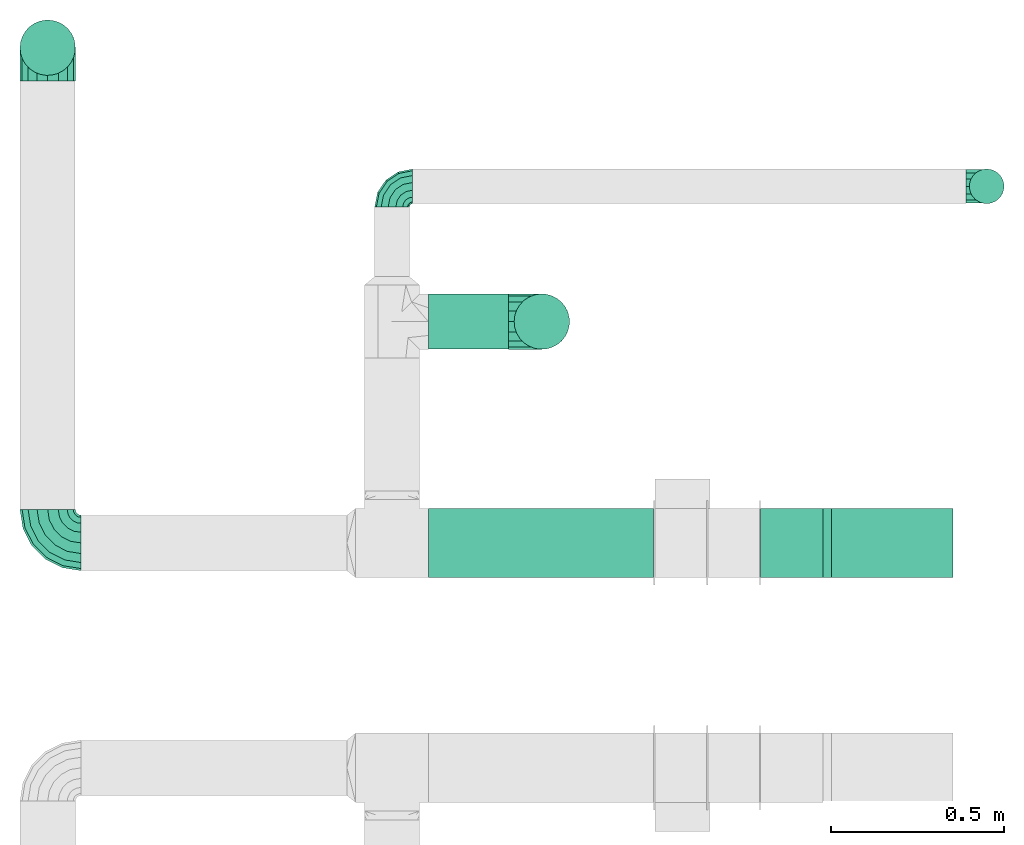
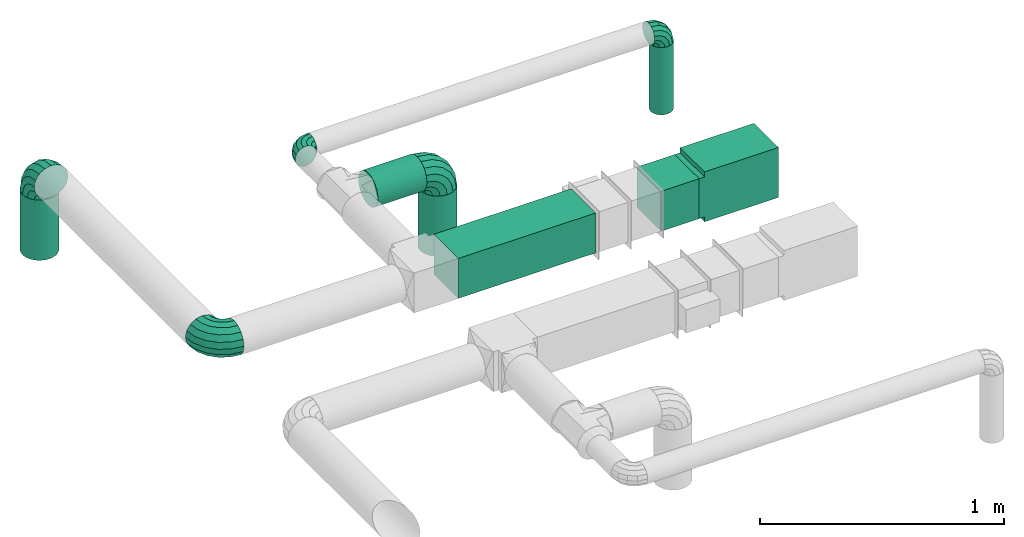
# One storey, part 2 of 5: 6 flow fittings, 6 flow segments.
"""IFC2X3 building model written with IfcOpenShell, lengths in millimetres."""

from ifc_helpers import new_model, entity, si_unit, converted_unit, derived_unit, direction, frame, frame_2d, origin, origin_2d_with_axis, place, context, subcontext, project, spatial, polyline, rectangle, circle, outline, extrude, faceted_brep, source, transform, mapped, material, type_object, type_shapes, element, save


model = new_model("IFC2X3")

# Units and contexts
model_context = context("Model", 3, precision=0.01, world=origin(), true_north=direction((6.12303176911189e-17, 1.0)))
body_context = subcontext(model_context, "Body", "Model", "MODEL_VIEW")
ifc_project = project(units=[si_unit("LENGTHUNIT", "METRE", prefix="MILLI"), si_unit("AREAUNIT", "SQUARE_METRE"), si_unit("VOLUMEUNIT", "CUBIC_METRE"), converted_unit("PLANEANGLEUNIT", "DEGREE", entity("IfcRatioMeasure", 0.0174532925199433), si_unit("PLANEANGLEUNIT", "RADIAN"), dimensions=[0, 0, 0, 0, 0, 0, 0]), si_unit("MASSUNIT", "GRAM", prefix="KILO"), derived_unit("MASSDENSITYUNIT", [(si_unit("MASSUNIT", "GRAM", prefix="KILO"), 1), (si_unit("LENGTHUNIT", "METRE"), -3)]), derived_unit("MOMENTOFINERTIAUNIT", [(si_unit("LENGTHUNIT", "METRE"), 4)]), si_unit("TIMEUNIT", "SECOND"), si_unit("FREQUENCYUNIT", "HERTZ"), si_unit("THERMODYNAMICTEMPERATUREUNIT", "DEGREE_CELSIUS"), derived_unit("THERMALTRANSMITTANCEUNIT", [(si_unit("MASSUNIT", "GRAM", prefix="KILO"), 1), (si_unit("THERMODYNAMICTEMPERATUREUNIT", "KELVIN"), -1), (si_unit("TIMEUNIT", "SECOND"), -3)]), derived_unit("VOLUMETRICFLOWRATEUNIT", [(si_unit("LENGTHUNIT", "METRE"), 3), (si_unit("TIMEUNIT", "SECOND"), -1)]), si_unit("ELECTRICCURRENTUNIT", "AMPERE"), si_unit("ELECTRICVOLTAGEUNIT", "VOLT"), si_unit("POWERUNIT", "WATT"), si_unit("FORCEUNIT", "NEWTON", prefix="KILO"), si_unit("ILLUMINANCEUNIT", "LUX"), si_unit("LUMINOUSFLUXUNIT", "LUMEN"), si_unit("LUMINOUSINTENSITYUNIT", "CANDELA"), derived_unit("USERDEFINED", [(si_unit("MASSUNIT", "GRAM", prefix="KILO"), -1), (si_unit("LENGTHUNIT", "METRE"), -2), (si_unit("TIMEUNIT", "SECOND"), 3), (si_unit("LUMINOUSFLUXUNIT", "LUMEN"), 1)]), derived_unit("LINEARVELOCITYUNIT", [(si_unit("LENGTHUNIT", "METRE"), 1), (si_unit("TIMEUNIT", "SECOND"), -1)]), si_unit("PRESSUREUNIT", "PASCAL"), derived_unit("USERDEFINED", [(si_unit("LENGTHUNIT", "METRE"), -2), (si_unit("MASSUNIT", "GRAM", prefix="KILO"), 1), (si_unit("TIMEUNIT", "SECOND"), -2)]), derived_unit("LINEARFORCEUNIT", [(si_unit("MASSUNIT", "GRAM", prefix="KILO"), 1), (si_unit("LENGTHUNIT", "METRE"), 1), (si_unit("TIMEUNIT", "SECOND"), -2), (si_unit("LENGTHUNIT", "METRE"), -1)]), derived_unit("PLANARFORCEUNIT", [(si_unit("MASSUNIT", "GRAM", prefix="KILO"), 1), (si_unit("LENGTHUNIT", "METRE"), 1), (si_unit("TIMEUNIT", "SECOND"), -2), (si_unit("LENGTHUNIT", "METRE"), -2)])], contexts=[model_context])

# Site, building, storey
site_placement = place(None, origin())
site = spatial("IfcSite", under=ifc_project, at=site_placement, CompositionType="ELEMENT")
building_placement = place(site_placement, origin())
building = spatial("IfcBuilding", under=site, at=building_placement, CompositionType="ELEMENT")
storey_placement = place(building_placement, frame((0.0, 0.0, 12000.0)))
storey = spatial("IfcBuildingStorey", under=building, at=storey_placement, Name="03 Level", CompositionType="ELEMENT", Elevation=12000.0)

# Flow segments
ifc_material = material()
duct_segment_type_1 = type_object("IfcDuctSegmentType", Name="Rectangular Duct:Air", PredefinedType="NOTDEFINED", material=ifc_material)
flow_segment_1_placement = place(storey_placement, origin())
element("IfcFlowSegment", 1, at=flow_segment_1_placement, inside=storey, type_object=duct_segment_type_1, Name="Rectangular Duct:Air", ObjectType="Rectangular Duct:Air", context=body_context, shape_type="SweptSolid", body=[
    extrude(rectangle(XDim=179.671447124557, YDim=199.999999999998, at=frame_2d((0.0, -4.33431068813661e-12), x_axis=(1.0, 0.0))), frame((24340.8257944141, -68506.4439409626, 2900.0)), (0.0, 0.0, 1.0), 199.999999999998),
])
flow_segment_2_placement = place(storey_placement, origin())
element("IfcFlowSegment", 2, at=flow_segment_2_placement, inside=storey, type_object=duct_segment_type_1, Name="Rectangular Duct:Air", ObjectType="Rectangular Duct:Air", context=body_context, shape_type="SweptSolid", body=[
    extrude(rectangle(XDim=650.000000000004, YDim=199.999999999998, at=frame_2d((-2.1600499167107e-12, -4.33431068813661e-12), x_axis=(1.0, 0.0))), frame((23615.9900708518, -68506.4439409626, 2900.0), z_axis=(0.0, 0.0, 1.0), x_axis=(-1.0, 0.0, 0.0)), (0.0, 0.0, 1.0), 199.999999999998),
])
duct_segment_type_2 = type_object("IfcDuctSegmentType", Name="Round Duct:Air", PredefinedType="NOTDEFINED", material=ifc_material)
flow_segment_3_placement = place(storey_placement, origin())
element("IfcFlowSegment", 3, at=flow_segment_3_placement, inside=storey, type_object=duct_segment_type_2, Name="Round Duct:Air", ObjectType="Round Duct:Air", context=body_context, shape_type="SweptSolid", body=[
    extrude(circle(Radius=80.0, at=origin_2d_with_axis()), frame((23290.9900708518, -67867.2449387878, 3000.0), z_axis=(1.0, 0.0, 0.0), x_axis=(0.0, 1.0, 0.0)), (0.0, 0.0, 1.0), 231.770344008329),
])
flow_segment_4_placement = place(storey_placement, origin())
element("IfcFlowSegment", 4, at=flow_segment_4_placement, inside=storey, type_object=duct_segment_type_2, Name="Round Duct:Air", ObjectType="Round Duct:Air", context=body_context, shape_type="SweptSolid", body=[
    extrude(circle(Radius=50.0, at=origin_2d_with_axis()), frame((24903.4900708518, -67476.5435577889, 2603.07847999999), z_axis=(0.0, 0.0, 1.0), x_axis=(0.0, 1.0, 0.0)), (0.0, 0.0, 1.0), 336.921519999948),
])
flow_segment_5_placement = place(storey_placement, origin())
element("IfcFlowSegment", 5, at=flow_segment_5_placement, inside=storey, type_object=duct_segment_type_2, Name="Round Duct:Air", ObjectType="Round Duct:Air", context=body_context, shape_type="SweptSolid", body=[
    extrude(circle(Radius=79.9999999999999, at=origin_2d_with_axis()), frame((23618.7604148601, -67867.2449387878, 2603.07847999999), z_axis=(0.0, 0.0, 1.0), x_axis=(-1.0, 0.0, 0.0)), (0.0, 0.0, 1.0), 300.921520000008),
])
flow_segment_6_placement = place(storey_placement, origin())
element("IfcFlowSegment", 6, at=flow_segment_6_placement, inside=storey, type_object=duct_segment_type_2, Name="Round Duct:Air", ObjectType="Round Duct:Air", context=body_context, shape_type="SweptSolid", body=[
    extrude(circle(Radius=79.9999999999999, at=origin_2d_with_axis()), frame((22191.748982204, -67076.2395851399, 2603.07847999999), z_axis=(0.0, 0.0, 1.0), x_axis=(-1.0, 0.0, 0.0)), (0.0, 0.0, 1.0), 300.921520000008),
])

# Flow fittings
duct_fitting_type_1 = type_object("IfcDuctFittingType", Name="elbow_short_001:Air_Elbow short_Circ", PredefinedType="NOTDEFINED")
shared_shape_1 = source(origin(), body_context, "Body", "Brep", [
    faceted_brep([(-17.9048224398387, 41.6267485762413, 0.0), (-19.7997011169438, 37.0521067749226, -21.6941869558777), (-60.0, 45.048443395121, -21.6941869558777), (-60.0, 50.0, 0.0), (-25.1090331870966, 24.2342452840172, -39.0915741234013), (-60.0, 31.1744900929368, -39.0915741234013), (-32.7812403191188, 5.71189877255398, -48.7463956090911), (-60.0, 11.1260466978159, -48.7463956090911), (-41.2967477970676, -14.8463548711994, -48.7463956090912), (-60.0, -11.1260466978154, -48.7463956090912), (-48.9689549290897, -33.3687013826628, -39.0915741234016), (-60.0, -31.1744900929364, -39.0915741234016), (-54.2782869992427, -46.1865628735683, -21.6941869558781), (-60.0, -45.0484433951208, -21.6941869558781), (-56.1731656763478, -50.7612046748872, 0.0), (-60.0, -50.0, 0.0), (-54.2782869992427, -46.1865628735684, 21.6941869558778), (-60.0, -45.0484433951209, 21.6941869558778), (-48.9689549290898, -33.368701382663, 39.0915741234014), (-60.0, -31.1744900929367, 39.0915741234014), (-41.2967477970677, -14.8463548711997, 48.7463956090911), (-60.0, -11.1260466978158, 48.7463956090911), (-32.7812403191189, 5.71189877255367, 48.7463956090912), (-60.0, 11.1260466978156, 48.7463956090912), (-25.1090331870968, 24.234245284017, 39.0915741234015), (-60.0, 31.1744900929365, 39.0915741234015), (-19.7997011169439, 37.0521067749224, 21.694186955878), (-60.0, 45.0484433951209, 21.694186955878), (17.7817459305218, 17.7817459305197, 0.0), (14.2804666777829, 14.2804666777808, -21.6941869558777), (4.47010021594292, 4.47010021594087, -39.0915741234013), (-9.70629006098175, -9.70629006098372, -48.7463956090911), (-25.4408961966291, -25.440896196631, -48.7463956090912), (-39.6172864735539, -39.6172864735557, -39.0915741234016), (-49.4276529353939, -49.4276529353957, -21.6941869558781), (-52.928932188133, -52.9289321881348, 0.0), (-49.427652935394, -49.4276529353958, 21.6941869558778), (-39.6172864735541, -39.6172864735559, 39.0915741234014), (-25.4408961966294, -25.4408961966313, 48.7463956090911), (-9.70629006098199, -9.70629006098396, 48.7463956090912), (4.47010021594272, 4.47010021594067, 39.0915741234015), (14.2804666777828, 14.2804666777807, 21.694186955878), (41.6267485762432, -17.9048224398409, 0.0), (37.0521067749244, -19.799701116946, -21.6941869558777), (24.2342452840191, -25.1090331870988, -39.0915741234013), (5.71189877255578, -32.7812403191208, -48.7463956090911), (-14.8463548711976, -41.2967477970696, -48.7463956090912), (-33.3687013826611, -48.9689549290916, -39.0915741234016), (-46.1865628735666, -54.2782869992445, -21.6941869558781), (-50.7612046748855, -56.1731656763497, 0.0), (-46.1865628735667, -54.2782869992445, 21.6941869558778), (-33.3687013826613, -48.9689549290917, 39.0915741234014), (-14.846354871198, -41.2967477970697, 48.7463956090911), (5.71189877255546, -32.781240319121, 48.7463956090912), (24.2342452840188, -25.1090331870989, 39.0915741234015), (37.0521067749243, -19.7997011169461, 21.694186955878), (50.0, -60.0, 0.0), (45.0484433951226, -60.0, -21.6941869558777), (31.1744900929384, -60.0, -39.0915741234013), (11.1260466978175, -60.0, -48.7463956090911), (-11.1260466978138, -60.0, -48.7463956090912), (-31.1744900929348, -60.0, -39.0915741234016), (-45.0484433951192, -60.0, -21.6941869558781), (-50.0, -60.0, 0.0), (-45.0484433951193, -60.0, 21.6941869558778), (-31.1744900929351, -60.0, 39.0915741234014), (-11.1260466978142, -60.0, 48.7463956090911), (11.1260466978172, -60.0, 48.7463956090912), (31.1744900929381, -60.0, 39.0915741234015), (45.0484433951225, -60.0, 21.694186955878)], [[[0, 1, 2, 3]], [[1, 4, 5, 2]], [[4, 6, 7, 5]], [[6, 8, 9, 7]], [[8, 10, 11, 9]], [[10, 12, 13, 11]], [[12, 14, 15, 13]], [[14, 16, 17, 15]], [[16, 18, 19, 17]], [[18, 20, 21, 19]], [[20, 22, 23, 21]], [[22, 24, 25, 23]], [[24, 26, 27, 25]], [[26, 0, 3, 27]], [[28, 29, 1, 0]], [[29, 30, 4, 1]], [[30, 31, 6, 4]], [[31, 32, 8, 6]], [[32, 33, 10, 8]], [[33, 34, 12, 10]], [[34, 35, 14, 12]], [[35, 36, 16, 14]], [[36, 37, 18, 16]], [[37, 38, 20, 18]], [[38, 39, 22, 20]], [[39, 40, 24, 22]], [[40, 41, 26, 24]], [[41, 28, 0, 26]], [[42, 43, 29, 28]], [[43, 44, 30, 29]], [[44, 45, 31, 30]], [[45, 46, 32, 31]], [[46, 47, 33, 32]], [[47, 48, 34, 33]], [[48, 49, 35, 34]], [[49, 50, 36, 35]], [[50, 51, 37, 36]], [[51, 52, 38, 37]], [[52, 53, 39, 38]], [[53, 54, 40, 39]], [[54, 55, 41, 40]], [[55, 42, 28, 41]], [[56, 57, 43, 42]], [[57, 58, 44, 43]], [[58, 59, 45, 44]], [[59, 60, 46, 45]], [[60, 61, 47, 46]], [[61, 62, 48, 47]], [[62, 63, 49, 48]], [[63, 64, 50, 49]], [[64, 65, 51, 50]], [[65, 66, 52, 51]], [[66, 67, 53, 52]], [[67, 68, 54, 53]], [[68, 69, 55, 54]], [[69, 56, 42, 55]], [[3, 2, 5, 7, 9, 11, 13, 15, 17, 19, 21, 23, 25, 27]], [[69, 68, 67, 66, 65, 64, 63, 62, 61, 60, 59, 58, 57, 56]]]),
])
type_shapes(duct_fitting_type_1, [shared_shape_1])
for number, where, z_axis, x_axis, name in (
    (7, (24903.4900708518, -67476.5435577884, 3000.0), (0.0, 1.0, 0.0), (0.0, 0.0, 1.0), "elbow_short_001:Air_Elbow short_Circ"),
    (8, (23185.9900708518, -67476.5435577883, 3000.0), (0.0, 0.0, 1.0), (0.0, 1.0, 0.0), "elbow_short_001:Air_Elbow short_Circ"),
):
    element("IfcFlowFitting", number, at=place(storey_placement, frame(where, z_axis=z_axis, x_axis=x_axis)), inside=storey, type_object=duct_fitting_type_1, Name=name, ObjectType="elbow_short_001:Air_Elbow short_Circ", context=body_context, shape_type="MappedRepresentation", body=[
        mapped(shared_shape_1, transform((0.0, 0.0, 0.0), scale=1.0)),
    ])
duct_fitting_type_2 = type_object("IfcDuctFittingType", Name="elbow_short_001:Air_Elbow short_Circ", PredefinedType="NOTDEFINED")
shared_shape_2 = source(origin(), body_context, "Body", "Brep", [
    faceted_brep([(-41.6130089900078, 71.3859468679469, 0.0), (-43.49481043591, 65.594357537661, -30.6146745892069), (-96.0, 73.9103626009031, -30.6146745892069), (-96.0, 80.0, 0.0), (-48.8537275620507, 49.1013065214514, -56.5685424949235), (-96.0, 56.5685424949241, -56.5685424949235), (-56.8739138146797, 24.417711326656, -73.9103626009028), (-96.0, 30.6146745892075, -73.9103626009028), (-66.3343685400036, -4.69857443566497, -80.0), (-96.0, 0.0, -80.0), (-75.7948232653275, -33.8148601979862, -73.9103626009031), (-96.0, -30.6146745892068, -73.9103626009031), (-83.8150095179566, -58.4984553927816, -56.5685424949241), (-96.0, -56.5685424949235, -56.5685424949241), (-89.1739266440973, -74.9915064089915, -30.6146745892076), (-96.0, -73.9103626009028, -30.6146745892076), (-91.0557280899996, -80.7830957392776, 0.0), (-96.0, -80.0, 0.0), (-89.1739266440974, -74.9915064089917, 30.6146745892071), (-96.0, -73.910362600903, 30.6146745892071), (-83.8150095179567, -58.498455392782, 56.5685424949237), (-96.0, -56.5685424949239, 56.5685424949237), (-75.7948232653277, -33.8148601979866, 73.9103626009029), (-96.0, -30.6146745892073, 73.9103626009029), (-66.3343685400038, -4.69857443566555, 80.0), (-96.0, 0.0, 80.0), (-56.8739138146798, 24.4177113266556, 73.910362600903), (-96.0, 30.614674589207, 73.910362600903), (-48.8537275620508, 49.101306521451, 56.568542494924), (-96.0, 56.5685424949236, 56.568542494924), (-43.49481043591, 65.5943575376609, 30.6146745892074), (-96.0, 73.9103626009029, 30.6146745892074), (7.45020440347688, 46.3869910099904, 0.0), (3.870805348479, 41.4603708645397, -30.6146745892069), (-6.32246075772457, 27.4305436854096, -56.5685424949235), (-21.5777615526518, 6.43342347992235, -73.9103626009028), (-39.5726157799208, -18.334368540005, -80.0), (-57.56747000719, -43.1021605599325, -73.9103626009031), (-72.8227708021172, -64.0992807654198, -56.5685424949241), (-83.016036908321, -78.1291079445501, -30.6146745892076), (-86.595435963319, -83.0557280900011, 0.0), (-83.0160369083211, -78.1291079445503, 30.6146745892071), (-72.8227708021175, -64.0992807654201, 56.5685424949237), (-57.5674700071903, -43.1021605599329, 73.9103626009029), (-39.5726157799212, -18.3343685400055, 80.0), (-21.577761552652, 6.43342347992197, 73.910362600903), (-6.32246075772481, 27.4305436854092, 56.568542494924), (3.87080534847888, 41.4603708645395, 30.6146745892074), (46.3869910099924, 7.45020440347469, 0.0), (41.4603708645417, 3.87080534847682, -30.6146745892069), (27.4305436854116, -6.3224607577267, -56.5685424949235), (6.43342347992429, -21.5777615526538, -73.9103626009028), (-18.3343685400031, -39.5726157799228, -80.0), (-43.1021605599306, -57.5674700071919, -73.9103626009031), (-64.099280765418, -72.8227708021191, -56.5685424949241), (-78.1291079445484, -83.0160369083228, -30.6146745892076), (-83.0557280899993, -86.5954359633209, 0.0), (-78.1291079445485, -83.0160369083229, 30.6146745892071), (-64.0992807654183, -72.8227708021194, 56.5685424949237), (-43.102160559931, -57.5674700071922, 73.9103626009029), (-18.3343685400036, -39.5726157799232, 80.0), (6.43342347992391, -21.5777615526541, 73.910362600903), (27.4305436854112, -6.32246075772694, 56.568542494924), (41.4603708645416, 3.87080534847671, 30.6146745892074), (71.3859468679487, -41.6130089900101, 0.0), (65.5943575376629, -43.4948104359123, -30.6146745892069), (49.1013065214533, -48.8537275620529, -56.5685424949235), (24.4177113266578, -56.8739138146818, -73.9103626009028), (-4.69857443566317, -66.3343685400057, -80.0), (-33.8148601979844, -75.7948232653295, -73.9103626009031), (-58.4984553927799, -83.8150095179585, -56.5685424949241), (-74.9915064089898, -89.1739266440992, -30.6146745892076), (-80.7830957392759, -91.0557280900015, 0.0), (-74.99150640899, -89.1739266440993, 30.6146745892071), (-58.4984553927803, -83.8150095179586, 56.5685424949237), (-33.8148601979849, -75.7948232653297, 73.9103626009029), (-4.69857443566375, -66.3343685400058, 80.0), (24.4177113266574, -56.873913814682, 73.910362600903), (49.1013065214529, -48.853727562053, 56.568542494924), (65.5943575376627, -43.4948104359123, 30.6146745892074), (80.0, -96.0, 0.0), (73.9103626009047, -96.0, -30.6146745892069), (56.5685424949257, -96.0, -56.5685424949235), (30.6146745892091, -96.0, -73.9103626009028), (0.0, -96.0, -80.0), (-30.6146745892051, -96.0, -73.9103626009031), (-56.5685424949218, -96.0, -56.5685424949241), (-73.9103626009011, -96.0, -30.6146745892076), (-80.0, -96.0, 0.0), (-73.9103626009013, -96.0, 30.6146745892071), (-56.5685424949222, -96.0, 56.5685424949237), (-30.6146745892057, -96.0, 73.9103626009029), (0.0, -96.0, 80.0), (30.6146745892087, -96.0, 73.910362600903), (56.5685424949253, -96.0, 56.568542494924), (73.9103626009045, -96.0, 30.6146745892074)], [[[0, 1, 2, 3]], [[1, 4, 5, 2]], [[4, 6, 7, 5]], [[6, 8, 9, 7]], [[8, 10, 11, 9]], [[10, 12, 13, 11]], [[12, 14, 15, 13]], [[14, 16, 17, 15]], [[16, 18, 19, 17]], [[18, 20, 21, 19]], [[20, 22, 23, 21]], [[22, 24, 25, 23]], [[24, 26, 27, 25]], [[26, 28, 29, 27]], [[28, 30, 31, 29]], [[30, 0, 3, 31]], [[32, 33, 1, 0]], [[33, 34, 4, 1]], [[34, 35, 6, 4]], [[35, 36, 8, 6]], [[36, 37, 10, 8]], [[37, 38, 12, 10]], [[38, 39, 14, 12]], [[39, 40, 16, 14]], [[40, 41, 18, 16]], [[41, 42, 20, 18]], [[42, 43, 22, 20]], [[43, 44, 24, 22]], [[44, 45, 26, 24]], [[45, 46, 28, 26]], [[46, 47, 30, 28]], [[47, 32, 0, 30]], [[48, 49, 33, 32]], [[49, 50, 34, 33]], [[50, 51, 35, 34]], [[51, 52, 36, 35]], [[52, 53, 37, 36]], [[53, 54, 38, 37]], [[54, 55, 39, 38]], [[55, 56, 40, 39]], [[56, 57, 41, 40]], [[57, 58, 42, 41]], [[58, 59, 43, 42]], [[59, 60, 44, 43]], [[60, 61, 45, 44]], [[61, 62, 46, 45]], [[62, 63, 47, 46]], [[63, 48, 32, 47]], [[64, 65, 49, 48]], [[65, 66, 50, 49]], [[66, 67, 51, 50]], [[67, 68, 52, 51]], [[68, 69, 53, 52]], [[69, 70, 54, 53]], [[70, 71, 55, 54]], [[71, 72, 56, 55]], [[72, 73, 57, 56]], [[73, 74, 58, 57]], [[74, 75, 59, 58]], [[75, 76, 60, 59]], [[76, 77, 61, 60]], [[77, 78, 62, 61]], [[78, 79, 63, 62]], [[79, 64, 48, 63]], [[80, 81, 65, 64]], [[81, 82, 66, 65]], [[82, 83, 67, 66]], [[83, 84, 68, 67]], [[84, 85, 69, 68]], [[85, 86, 70, 69]], [[86, 87, 71, 70]], [[87, 88, 72, 71]], [[88, 89, 73, 72]], [[89, 90, 74, 73]], [[90, 91, 75, 74]], [[91, 92, 76, 75]], [[92, 93, 77, 76]], [[93, 94, 78, 77]], [[94, 95, 79, 78]], [[95, 80, 64, 79]], [[3, 2, 5, 7, 9, 11, 13, 15, 17, 19, 21, 23, 25, 27, 29, 31]], [[95, 94, 93, 92, 91, 90, 89, 88, 87, 86, 85, 84, 83, 82, 81, 80]]]),
])
type_shapes(duct_fitting_type_2, [shared_shape_2])
for number, where, z_axis, x_axis, name in (
    (9, (23618.7604148601, -67867.2449387878, 3000.0), (0.0, 1.0, 0.0), (0.0, 0.0, 1.0), "elbow_short_001:Air_Elbow short_Circ"),
    (10, (22191.748982204, -67076.2395851399, 3000.0), (-1.0, 0.0, 0.0), (0.0, 0.0, 1.0), "elbow_short_001:Air_Elbow short_Circ"),
    (11, (22191.748982204, -68506.4439409626, 3000.0), (0.0, 0.0, 1.0), (-1.0, 0.0, 0.0), "elbow_short_001:Air_Elbow short_Circ"),
):
    element("IfcFlowFitting", number, at=place(storey_placement, frame(where, z_axis=z_axis, x_axis=x_axis)), inside=storey, type_object=duct_fitting_type_2, Name=name, ObjectType="elbow_short_001:Air_Elbow short_Circ", context=body_context, shape_type="MappedRepresentation", body=[
        mapped(shared_shape_2, transform((0.0, 0.0, 0.0), scale=1.0)),
    ])
duct_fitting_type_3 = type_object("IfcDuctFittingType", Name="1_001:Air_Rect", PredefinedType="NOTDEFINED")
shared_shape_3 = source(origin(), body_context, "Body", "SweptSolid", [
    extrude(outline(polyline([(-81.2499999999996, -125.0), (268.75, -125.0), (268.75, 125.0), (-81.2500000000004, 125.0), (-81.2500000000003, 100.0), (-106.25, 100.0), (-106.25, -100.0), (-81.2499999999997, -100.0), (-81.2499999999996, -125.0)])), frame((0.0, 93.75, -100.0), z_axis=(0.0, 0.0, 1.0), x_axis=(0.0, -1.0, 0.0)), (0.0, 0.0, 1.0), 200.0),
])
type_shapes(duct_fitting_type_3, [shared_shape_3])
flow_fitting_placement = place(storey_placement, frame((24630.6615179764, -68506.4439409627, 3000.0), z_axis=(0.0, 1.0, 0.0), x_axis=(0.0, 0.0, -1.0)))
element("IfcFlowFitting", 12, at=flow_fitting_placement, inside=storey, type_object=duct_fitting_type_3, Name="1_001:Air_Rect", ObjectType="1_001:Air_Rect", context=body_context, shape_type="MappedRepresentation", body=[
    mapped(shared_shape_3, transform((0.0, 0.0, 0.0), scale=1.0)),
])

save(model, "model.ifc")
